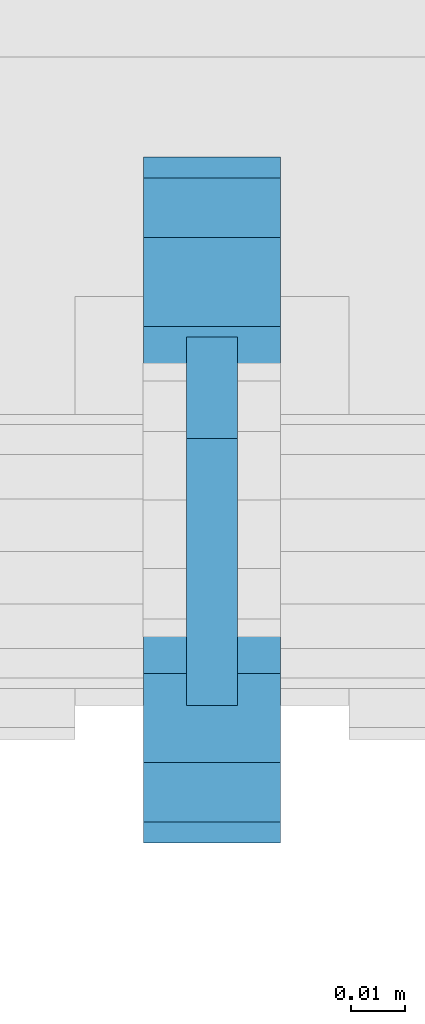
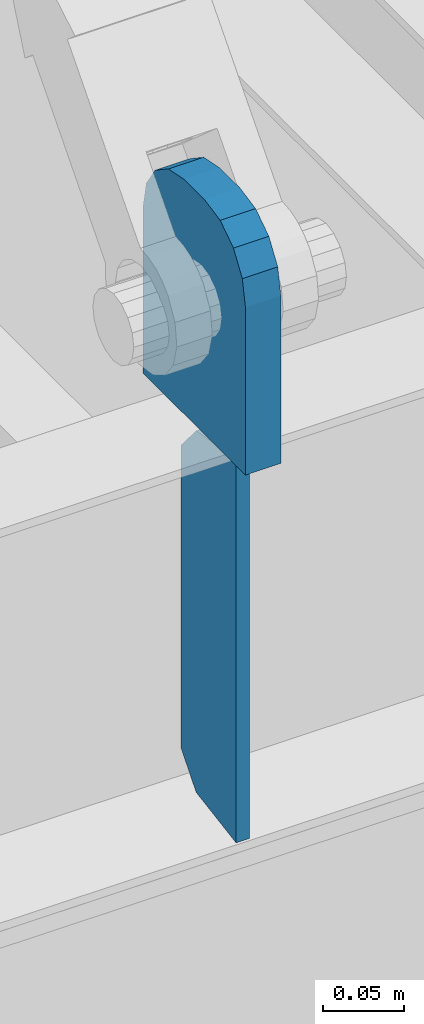
# One storey, part 1462 of 1763: 2 plates, 1 element without a shape of its own.
"""IFC2X3 building model written with IfcOpenShell, lengths in millimetres."""

from ifc_helpers import new_model, si_unit, frame, origin_with_axes, place, context, subcontext, project, spatial, faceted_brep, material, type_object, element, aggregate, save


model = new_model("IFC2X3")

# Units and contexts
model_context = context("Model", 3, precision=1e-05, world=origin_with_axes())
body_context = subcontext(model_context, "Body", "Model", "MODEL_VIEW")
ifc_project = project(units=[si_unit("LENGTHUNIT", "METRE", prefix="MILLI"), si_unit("AREAUNIT", "SQUARE_METRE"), si_unit("VOLUMEUNIT", "CUBIC_METRE"), si_unit("MASSUNIT", "GRAM", prefix="KILO"), si_unit("TIMEUNIT", "SECOND"), si_unit("PLANEANGLEUNIT", "RADIAN"), si_unit("SOLIDANGLEUNIT", "STERADIAN"), si_unit("THERMODYNAMICTEMPERATUREUNIT", "DEGREE_CELSIUS"), si_unit("LUMINOUSINTENSITYUNIT", "LUMEN")], contexts=[model_context])

# Site, building, storey
site_placement = place(None, origin_with_axes())
site = spatial("IfcSite", under=ifc_project, at=site_placement, CompositionType="ELEMENT")
building_placement = place(site_placement, origin_with_axes())
building = spatial("IfcBuilding", under=site, at=building_placement, Name="Undefined", CompositionType="ELEMENT")
storey_placement = place(building_placement, origin_with_axes())
storey = spatial("IfcBuildingStorey", under=building, at=storey_placement, Name="Undefined", CompositionType="ELEMENT", Elevation=0.0)

# Assembly, plates
assembly_placement = place(storey_placement, origin_with_axes())
assembly = element("IfcElementAssembly", 1, at=assembly_placement, inside=storey, Name="BEAM", AssemblyPlace="NOTDEFINED", PredefinedType="RIGID_FRAME")
ifc_material = material(Name="STEEL/A36")
plate_type_1 = type_object("IfcPlateType", PredefinedType="NOTDEFINED")
plate_1_placement = place(assembly_placement, frame((-49402.4270098473, -16681.452583792, 8440.7619207156), z_axis=(0.0, -0.164335003932505, 0.986404585594828), x_axis=(0.0, 0.986404585594827, 0.164335003932507)))
plate_1 = element("IfcPlate", 2, at=plate_1_placement, type_object=plate_type_1, material=ifc_material, Name="PLATE", context=body_context, shape_type="Brep", body=[
    faceted_brep([(0.0, -4.76249999999982, 0.0), (47.7369384761423, -4.76249999999709, 286.536254883109), (47.7369384761423, 4.76249999999709, 286.536254883109), (0.0, 4.76249999999982, 0.0), (95.1814043146169, -4.76249999999709, 270.276469957982), (95.1814043146169, 4.76249999999709, 270.276469957982), (110.071894935774, -4.76249999999709, 245.309426724465), (110.071894935774, 4.76249999999709, 245.309426724465), (72.333927817599, -4.76249999999709, 18.7910066254462), (72.333927817599, 4.76249999999709, 18.7910066254462), (50.1533470153317, -4.76249999999709, 3.09228198602796e-11), (50.1533470153317, 4.76249999999709, 3.09228198602796e-11)], [[[0, 1, 2, 3]], [[1, 4, 5, 2]], [[4, 6, 7, 5]], [[6, 8, 9, 7]], [[8, 10, 11, 9]], [[10, 0, 3, 11]], [[5, 7, 9, 11, 3, 2]], [[10, 8, 6, 4, 1, 0]]]),
])
plate_type_2 = type_object("IfcPlateType", PredefinedType="NOTDEFINED")
plate_2_placement = place(assembly_placement, frame((-49402.4270098473, -16706.8525869316, 8915.4), z_axis=(0.0, 1.0, 0.0), x_axis=(0.0, 0.0, -1.0)))
plate_2 = element("IfcPlate", 3, at=plate_2_placement, type_object=plate_type_2, material=ifc_material, Name="PLATE", context=body_context, shape_type="Brep", body=[
    faceted_brep([(0.0, -12.6999999999971, 50.7999992370605), (-5.45696821063757e-12, -12.7000000000098, 76.1999999999971), (5.45696821063757e-12, 12.7000000000116, 76.1999999999971), (0.0, 12.6999999999971, 50.7999992370605), (3.86691969035201, -12.6999999999971, 95.6403188351214), (3.86691969035201, 12.6999999999971, 95.6403188351214), (14.8789752922639, -12.6999999999971, 112.121024707736), (14.8789752922639, 12.6999999999971, 112.121024707736), (31.3596811648786, -12.6999999999971, 123.13308030965), (31.3596811648786, 12.6999999999971, 123.13308030965), (50.7999992370605, -12.6999999999971, 127.0), (50.7999992370605, 12.6999999999971, 127.0), (177.800003051758, -12.6999999999971, 127.0), (177.800003051758, 12.6999999999971, 127.0), (177.800003051758, -12.6999999999971, 0.0), (177.800003051758, 12.6999999999971, 0.0), (50.7999992370605, -12.6999999999971, 0.0), (50.7999992370605, 12.6999999999971, 0.0), (31.3596811648786, -12.6999999999971, 3.86691969035019), (31.3596811648786, 12.6999999999971, 3.86691969035019), (14.8789752922639, -12.6999999999971, 14.8789752922639), (14.8789752922639, 12.6999999999971, 14.8789752922639), (3.86691969035201, -12.6999999999971, 31.3596811648786), (3.86691969035201, 12.6999999999971, 31.3596811648786)], [[[0, 1, 2, 3]], [[1, 4, 5, 2]], [[4, 6, 7, 5]], [[6, 8, 9, 7]], [[8, 10, 11, 9]], [[10, 12, 13, 11]], [[12, 14, 15, 13]], [[14, 16, 17, 15]], [[16, 18, 19, 17]], [[18, 20, 21, 19]], [[20, 22, 23, 21]], [[22, 0, 3, 23]], [[5, 7, 9, 11, 13, 15, 17, 19, 21, 23, 3, 2]], [[22, 20, 18, 16, 14, 12, 10, 8, 6, 4, 1, 0]]]),
])
aggregate(assembly, [plate_1, plate_2])

save(model, "model.ifc")
